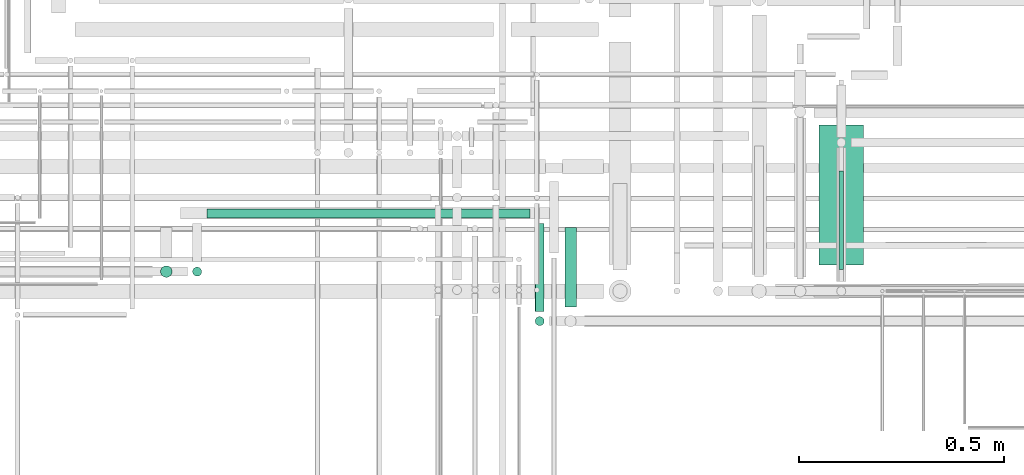
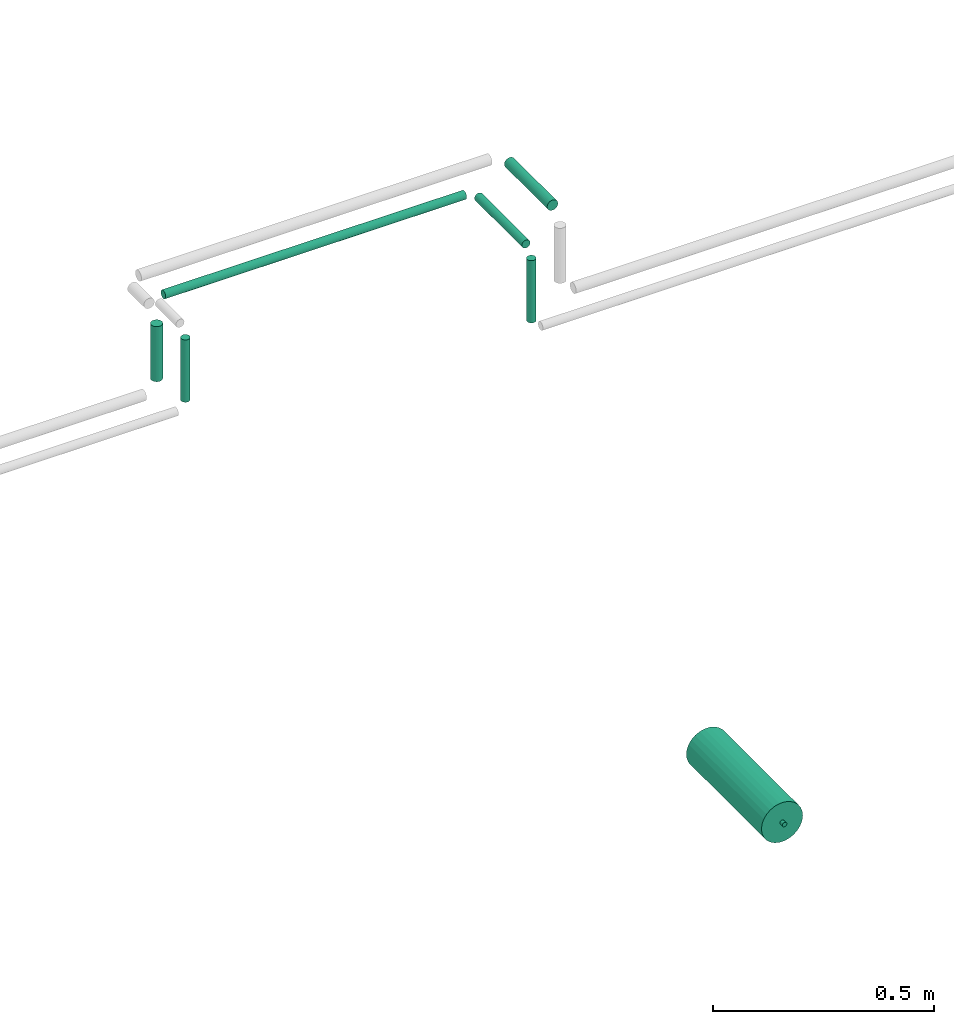
# One storey, part 223 of 331: 8 flow segments.
"""IFC2X3 building model written with IfcOpenShell, lengths in millimetres."""

from ifc_helpers import new_model, entity, si_unit, converted_unit, derived_unit, direction, frame, origin, origin_2d_with_axis, place, context, subcontext, project, spatial, circle, extrude, type_object, element, save


model = new_model("IFC2X3")

# Units and contexts
model_context = context("Model", 3, precision=0.01, world=origin(), true_north=direction((6.12303176911189e-17, 1.0)))
body_context = subcontext(model_context, "Body", "Model", "MODEL_VIEW")
ifc_project = project(units=[si_unit("LENGTHUNIT", "METRE", prefix="MILLI"), si_unit("AREAUNIT", "SQUARE_METRE"), si_unit("VOLUMEUNIT", "CUBIC_METRE"), converted_unit("PLANEANGLEUNIT", "DEGREE", entity("IfcRatioMeasure", 0.0174532925199433), si_unit("PLANEANGLEUNIT", "RADIAN"), dimensions=[0, 0, 0, 0, 0, 0, 0]), si_unit("MASSUNIT", "GRAM", prefix="KILO"), derived_unit("MASSDENSITYUNIT", [(si_unit("MASSUNIT", "GRAM", prefix="KILO"), 1), (si_unit("LENGTHUNIT", "METRE"), -3)]), derived_unit("MOMENTOFINERTIAUNIT", [(si_unit("LENGTHUNIT", "METRE"), 4)]), si_unit("TIMEUNIT", "SECOND"), si_unit("FREQUENCYUNIT", "HERTZ"), si_unit("THERMODYNAMICTEMPERATUREUNIT", "DEGREE_CELSIUS"), derived_unit("THERMALTRANSMITTANCEUNIT", [(si_unit("MASSUNIT", "GRAM", prefix="KILO"), 1), (si_unit("THERMODYNAMICTEMPERATUREUNIT", "KELVIN"), -1), (si_unit("TIMEUNIT", "SECOND"), -3)]), derived_unit("VOLUMETRICFLOWRATEUNIT", [(si_unit("LENGTHUNIT", "METRE"), 3), (si_unit("TIMEUNIT", "SECOND"), -1)]), derived_unit("MASSFLOWRATEUNIT", [(si_unit("MASSUNIT", "GRAM", prefix="KILO"), 1), (si_unit("TIMEUNIT", "SECOND"), -1)]), derived_unit("ROTATIONALFREQUENCYUNIT", [(si_unit("TIMEUNIT", "SECOND"), -1)]), si_unit("ELECTRICCURRENTUNIT", "AMPERE"), si_unit("ELECTRICVOLTAGEUNIT", "VOLT"), si_unit("POWERUNIT", "WATT"), si_unit("FORCEUNIT", "NEWTON", prefix="KILO"), si_unit("ILLUMINANCEUNIT", "LUX"), si_unit("LUMINOUSFLUXUNIT", "LUMEN"), si_unit("LUMINOUSINTENSITYUNIT", "CANDELA"), derived_unit("USERDEFINED", [(si_unit("MASSUNIT", "GRAM", prefix="KILO"), -1), (si_unit("LENGTHUNIT", "METRE"), -2), (si_unit("TIMEUNIT", "SECOND"), 3), (si_unit("LUMINOUSFLUXUNIT", "LUMEN"), 1)]), derived_unit("LINEARVELOCITYUNIT", [(si_unit("LENGTHUNIT", "METRE"), 1), (si_unit("TIMEUNIT", "SECOND"), -1)]), si_unit("PRESSUREUNIT", "PASCAL"), derived_unit("USERDEFINED", [(si_unit("LENGTHUNIT", "METRE"), -2), (si_unit("MASSUNIT", "GRAM", prefix="KILO"), 1), (si_unit("TIMEUNIT", "SECOND"), -2)]), derived_unit("LINEARFORCEUNIT", [(si_unit("MASSUNIT", "GRAM", prefix="KILO"), 1), (si_unit("LENGTHUNIT", "METRE"), 1), (si_unit("TIMEUNIT", "SECOND"), -2), (si_unit("LENGTHUNIT", "METRE"), -1)]), derived_unit("PLANARFORCEUNIT", [(si_unit("MASSUNIT", "GRAM", prefix="KILO"), 1), (si_unit("LENGTHUNIT", "METRE"), 1), (si_unit("TIMEUNIT", "SECOND"), -2), (si_unit("LENGTHUNIT", "METRE"), -2)])], contexts=[model_context])

# Site, building, storey
site_placement = place(None, frame((0.0, -0.00077364408347762, 0.0)))
site = spatial("IfcSite", under=ifc_project, at=site_placement, CompositionType="ELEMENT")
building_placement = place(site_placement, origin())
building = spatial("IfcBuilding", under=site, at=building_placement, CompositionType="ELEMENT")
storey_placement = place(building_placement, origin())
storey = spatial("IfcBuildingStorey", under=building, at=storey_placement, CompositionType="ELEMENT", Elevation=0.0)

# Flow segments
pipe_segment_type = type_object("IfcPipeSegmentType", PredefinedType="NOTDEFINED")
flow_segment_1_placement = place(building_placement, frame((63576.4002481169, 8109.0, 2979.40472776409)))
element("IfcFlowSegment", 1, at=flow_segment_1_placement, inside=storey, type_object=pipe_segment_type, context=body_context, shape_type="SweptSolid", body=[
    extrude(circle(Radius=14.0, at=origin_2d_with_axis()), frame((15.5952722359127, 0.0, 15.595272235916), z_axis=(0.0, 1.0, 0.0), x_axis=(1.0, 0.0, 0.0)), (0.0, 0.0, 1.0), 194.000762939427),
])
flow_segment_2_placement = place(storey_placement, frame((64195.5166110417, 8212.0404278096, 942.404727764084)))
element("IfcFlowSegment", 2, at=flow_segment_2_placement, inside=storey, type_object=pipe_segment_type, context=body_context, shape_type="SweptSolid", body=[
    extrude(circle(Radius=54.0, at=origin_2d_with_axis()), frame((55.5952722359123, 0.0, 55.5952722359161), z_axis=(0.0, 1.0, 0.0), x_axis=(1.0, 0.0, 0.0)), (0.0, 0.0, 1.0), 340.0),
])
flow_segment_3_placement = place(storey_placement, frame((64243.5166110417, 8200.92940743144, 990.404727764084)))
element("IfcFlowSegment", 3, at=flow_segment_3_placement, inside=storey, type_object=pipe_segment_type, context=body_context, shape_type="SweptSolid", body=[
    extrude(circle(Radius=6.0, at=origin_2d_with_axis()), frame((7.59527223591454, 0.0, 7.59527223591603), z_axis=(0.0, 1.0, 0.0), x_axis=(1.0, 0.0, 0.0)), (0.0, 0.0, 1.0), 240.0),
])
flow_segment_4_placement = place(building_placement, frame((62706.9979617591, 8324.40549070351, 2907.40472776409)))
element("IfcFlowSegment", 4, at=flow_segment_4_placement, inside=storey, type_object=pipe_segment_type, context=body_context, shape_type="SweptSolid", body=[
    extrude(circle(Radius=11.0, at=origin_2d_with_axis()), frame((0.0, 12.5952722359156, 12.5952722359161), z_axis=(1.0, 0.0, 0.0), x_axis=(0.0, -1.0, 0.0)), (0.0, 0.0, 1.0), 785.997558593754),
])
flow_segment_5_placement = place(building_placement, frame((63504.4002481169, 8099.0, 2907.40472776409)))
element("IfcFlowSegment", 5, at=flow_segment_5_placement, inside=storey, type_object=pipe_segment_type, context=body_context, shape_type="SweptSolid", body=[
    extrude(circle(Radius=11.0, at=origin_2d_with_axis()), frame((12.5952722359134, 0.0, 12.5952722359161), z_axis=(0.0, 1.0, 0.0), x_axis=(1.0, 0.0, 0.0)), (0.0, 0.0, 1.0), 214.000762939425),
])
flow_segment_6_placement = place(building_placement, frame((63504.4002481169, 8062.40472776409, 2724.0)))
element("IfcFlowSegment", 6, at=flow_segment_6_placement, inside=storey, type_object=pipe_segment_type, context=body_context, shape_type="SweptSolid", body=[
    extrude(circle(Radius=11.0, at=origin_2d_with_axis()), frame((12.5952722359134, 12.5952722359156, 0.0), z_axis=(0.0, 0.0, 1.0), x_axis=(-1.0, 0.0, 0.0)), (0.0, 0.0, 1.0), 172.000000000011),
])
flow_segment_7_placement = place(building_placement, frame((62592.4026895232, 8179.92098945658, 2809.0)))
element("IfcFlowSegment", 7, at=flow_segment_7_placement, inside=storey, type_object=pipe_segment_type, context=body_context, shape_type="SweptSolid", body=[
    extrude(circle(Radius=14.0, at=origin_2d_with_axis()), frame((15.5952722359127, 15.595272235916, 0.0), z_axis=(0.0, 0.0, 1.0), x_axis=(-1.0, 0.0, 0.0)), (0.0, 0.0, 1.0), 152.000000000081),
])
flow_segment_8_placement = place(building_placement, frame((62670.4026895231, 8182.92098945658, 2724.0)))
element("IfcFlowSegment", 8, at=flow_segment_8_placement, inside=storey, type_object=pipe_segment_type, context=body_context, shape_type="SweptSolid", body=[
    extrude(circle(Radius=11.0, at=origin_2d_with_axis()), frame((12.5952722359134, 12.5952722359156, 0.0), z_axis=(0.0, 0.0, 1.0), x_axis=(-1.0, 0.0, 0.0)), (0.0, 0.0, 1.0), 172.000000000082),
])

save(model, "model.ifc")
